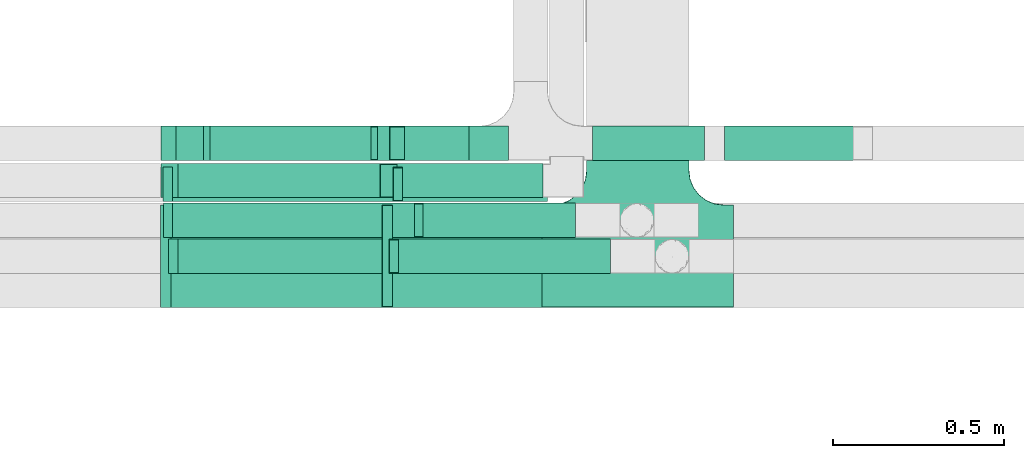
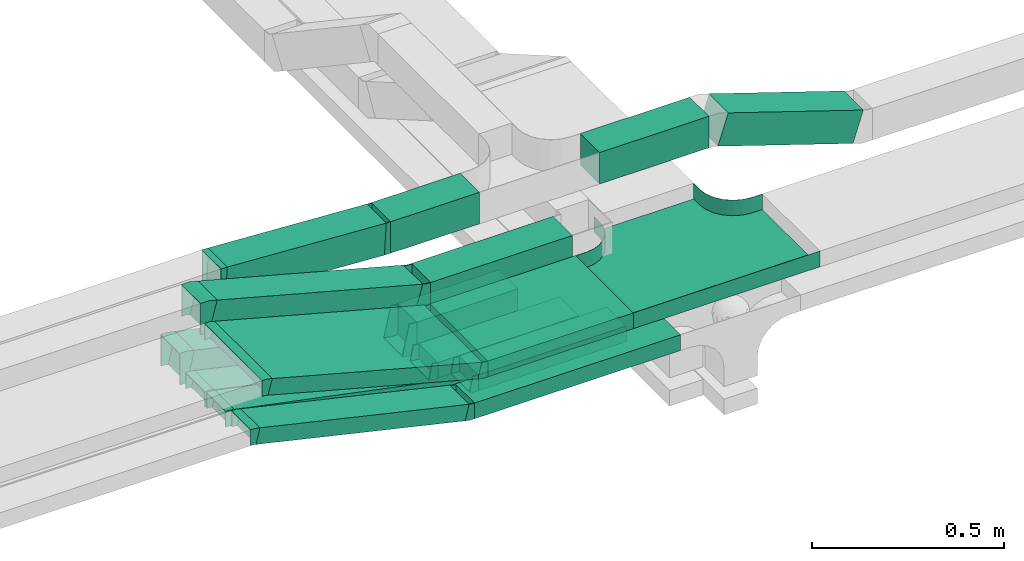
# One storey, part 10 of 14: 16 flow segments, 15 flow fittings.
"""IFC2X3 building model written with IfcOpenShell, lengths in millimetres."""

from ifc_helpers import new_model, entity, si_unit, converted_unit, derived_unit, direction, frame, frame_2d, origin, origin_2d_with_axis, place, context, subcontext, project, spatial, rectangle, extrude, faceted_brep, source, transform, mapped, material, type_object, type_shapes, element, save


model = new_model("IFC2X3")

# Units and contexts
model_context = context("Model", 3, precision=0.01, world=origin(), true_north=direction((6.12303176911189e-17, 1.0)))
body_context = subcontext(model_context, "Body", "Model", "MODEL_VIEW")
ifc_project = project(units=[si_unit("LENGTHUNIT", "METRE", prefix="MILLI"), si_unit("AREAUNIT", "SQUARE_METRE"), si_unit("VOLUMEUNIT", "CUBIC_METRE"), converted_unit("PLANEANGLEUNIT", "DEGREE", entity("IfcRatioMeasure", 0.0174532925199433), si_unit("PLANEANGLEUNIT", "RADIAN"), dimensions=[0, 0, 0, 0, 0, 0, 0]), si_unit("MASSUNIT", "GRAM", prefix="KILO"), derived_unit("MASSDENSITYUNIT", [(si_unit("MASSUNIT", "GRAM", prefix="KILO"), 1), (si_unit("LENGTHUNIT", "METRE"), -3)]), derived_unit("MOMENTOFINERTIAUNIT", [(si_unit("LENGTHUNIT", "METRE"), 4)]), si_unit("TIMEUNIT", "SECOND"), si_unit("FREQUENCYUNIT", "HERTZ"), si_unit("THERMODYNAMICTEMPERATUREUNIT", "DEGREE_CELSIUS"), derived_unit("THERMALTRANSMITTANCEUNIT", [(si_unit("MASSUNIT", "GRAM", prefix="KILO"), 1), (si_unit("THERMODYNAMICTEMPERATUREUNIT", "KELVIN"), -1), (si_unit("TIMEUNIT", "SECOND"), -3)]), derived_unit("VOLUMETRICFLOWRATEUNIT", [(si_unit("LENGTHUNIT", "METRE"), 3), (si_unit("TIMEUNIT", "SECOND"), -1)]), derived_unit("MASSFLOWRATEUNIT", [(si_unit("MASSUNIT", "GRAM", prefix="KILO"), 1), (si_unit("TIMEUNIT", "SECOND"), -1)]), derived_unit("ROTATIONALFREQUENCYUNIT", [(si_unit("TIMEUNIT", "SECOND"), -1)]), si_unit("ELECTRICCURRENTUNIT", "AMPERE"), si_unit("ELECTRICVOLTAGEUNIT", "VOLT"), si_unit("POWERUNIT", "WATT"), si_unit("FORCEUNIT", "NEWTON", prefix="KILO"), si_unit("ILLUMINANCEUNIT", "LUX"), si_unit("LUMINOUSFLUXUNIT", "LUMEN"), si_unit("LUMINOUSINTENSITYUNIT", "CANDELA"), derived_unit("USERDEFINED", [(si_unit("MASSUNIT", "GRAM", prefix="KILO"), -1), (si_unit("LENGTHUNIT", "METRE"), -2), (si_unit("TIMEUNIT", "SECOND"), 3), (si_unit("LUMINOUSFLUXUNIT", "LUMEN"), 1)]), derived_unit("LINEARVELOCITYUNIT", [(si_unit("LENGTHUNIT", "METRE"), 1), (si_unit("TIMEUNIT", "SECOND"), -1)]), si_unit("PRESSUREUNIT", "PASCAL"), derived_unit("USERDEFINED", [(si_unit("LENGTHUNIT", "METRE"), -2), (si_unit("MASSUNIT", "GRAM", prefix="KILO"), 1), (si_unit("TIMEUNIT", "SECOND"), -2)]), derived_unit("LINEARFORCEUNIT", [(si_unit("MASSUNIT", "GRAM", prefix="KILO"), 1), (si_unit("LENGTHUNIT", "METRE"), 1), (si_unit("TIMEUNIT", "SECOND"), -2), (si_unit("LENGTHUNIT", "METRE"), -1)]), derived_unit("PLANARFORCEUNIT", [(si_unit("MASSUNIT", "GRAM", prefix="KILO"), 1), (si_unit("LENGTHUNIT", "METRE"), 1), (si_unit("TIMEUNIT", "SECOND"), -2), (si_unit("LENGTHUNIT", "METRE"), -2)])], contexts=[model_context])

# Site, building, storey
site_placement = place(None, origin())
site = spatial("IfcSite", under=ifc_project, at=site_placement, CompositionType="ELEMENT")
building_placement = place(site_placement, origin())
building = spatial("IfcBuilding", under=site, at=building_placement, CompositionType="ELEMENT")
storey_placement = place(building_placement, frame((0.0, 0.0, 19800.0)))
storey = spatial("IfcBuildingStorey", under=building, at=storey_placement, Name="06", CompositionType="ELEMENT", Elevation=19800.0)

# Flow segments
cable_carrier_segment_type = type_object("IfcCableCarrierSegmentType", PredefinedType="CABLETRAYSEGMENT")
flow_segment_1_placement = place(storey_placement, frame((63840.22, 9836.0, 3000.0)))
element("IfcFlowSegment", 1, at=flow_segment_1_placement, inside=storey, type_object=cable_carrier_segment_type, context=body_context, shape_type="SweptSolid", body=[
    extrude(rectangle(XDim=425.328821775626, YDim=99.9999999999989, at=origin_2d_with_axis()), frame((212.66, 50.0, 0.0), z_axis=(0.0, 0.0, 1.0), x_axis=(-1.0, -2.08689464395144e-08, 0.0)), (0.0, 0.0, 1.0), 100.000000000008),
])
flow_segment_2_placement = place(storey_placement, frame((63916.07, 9720.0, 2800.0)))
element("IfcFlowSegment", 2, at=flow_segment_2_placement, inside=storey, type_object=cable_carrier_segment_type, context=body_context, shape_type="SweptSolid", body=[
    extrude(rectangle(XDim=444.461560115162, YDim=99.9999999999989, at=origin_2d_with_axis()), frame((222.23, 50.0, 0.0), z_axis=(0.0, 0.0, 1.0), x_axis=(-1.0, 0.0, 0.0)), (0.0, 0.0, 1.0), 49.9999999999973),
])
flow_segment_3_placement = place(storey_placement, frame((63861.59, 9945.0, 2800.0)))
element("IfcFlowSegment", 3, at=flow_segment_3_placement, inside=storey, type_object=cable_carrier_segment_type, context=body_context, shape_type="SweptSolid", body=[
    extrude(rectangle(XDim=303.534093712912, YDim=99.9999999999989, at=origin_2d_with_axis()), frame((151.77, 50.0, 0.0)), (0.0, 0.0, 1.0), 100.000000000003),
])
flow_segment_4_placement = place(storey_placement, frame((63844.36, 9615.0, 2800.0)))
element("IfcFlowSegment", 4, at=flow_segment_4_placement, inside=storey, type_object=cable_carrier_segment_type, context=body_context, shape_type="SweptSolid", body=[
    extrude(rectangle(XDim=618.676195552314, YDim=100.000000000001, at=origin_2d_with_axis()), frame((309.34, 50.0, 0.0), z_axis=(0.0, 0.0, 1.0), x_axis=(-1.0, 0.0, 0.0)), (0.0, 0.0, 1.0), 49.9999999999973),
])
flow_segment_5_placement = place(storey_placement, frame((64765.17, 9945.0, 3009.28)))
element("IfcFlowSegment", 5, at=flow_segment_5_placement, inside=storey, type_object=cable_carrier_segment_type, context=body_context, shape_type="SweptSolid", body=[
    extrude(rectangle(XDim=99.9999999999972, YDim=99.9999999999989, at=origin_2d_with_axis()), frame((15.59, 50.0, 180.61), z_axis=(0.950175096611784, 0.0, -0.311716675490399), x_axis=(0.311716675490399, 0.0, 0.950175096611784)), (0.0, 0.0, 1.0), 426.997112921798),
])
flow_segment_6_placement = place(storey_placement, frame((64410.06, 9945.0, 3146.68)))
element("IfcFlowSegment", 6, at=flow_segment_6_placement, inside=storey, type_object=cable_carrier_segment_type, context=body_context, shape_type="SweptSolid", body=[
    extrude(rectangle(XDim=328.216762954596, YDim=99.9999999999989, at=origin_2d_with_axis()), frame((164.11, 50.0, 0.0)), (0.0, 0.0, 1.0), 100.000000000003),
])
flow_segment_7_placement = place(storey_placement, frame((63826.54, 9515.0, 3000.0)))
element("IfcFlowSegment", 7, at=flow_segment_7_placement, inside=storey, type_object=cable_carrier_segment_type, context=body_context, shape_type="SweptSolid", body=[
    extrude(rectangle(XDim=436.498088942979, YDim=300.000000000001, at=origin_2d_with_axis()), frame((218.25, 150.0, 0.0), z_axis=(0.0, 0.0, 1.0), x_axis=(-1.0, 0.0, 0.0)), (0.0, 0.0, 1.0), 49.9999999999973),
])
flow_segment_8_placement = place(storey_placement, frame((63173.53, 9836.0, 3006.58)))
element("IfcFlowSegment", 8, at=flow_segment_8_placement, inside=storey, type_object=cable_carrier_segment_type, context=body_context, shape_type="SweptSolid", body=[
    extrude(rectangle(XDim=99.999999999999, YDim=99.9999999999989, at=frame_2d((0.0, 0.0), x_axis=(0.0, 1.0))), frame((12.94, 50.0, 213.55), z_axis=(0.965925826289069, 0.0, -0.258819045102519), x_axis=(0.0, 1.0, 0.0)), (0.0, 0.0, 1.0), 638.501182800934),
])
flow_segment_9_placement = place(storey_placement, frame((63166.54, 9515.0, 3004.02)))
element("IfcFlowSegment", 9, at=flow_segment_9_placement, inside=storey, type_object=cable_carrier_segment_type, context=body_context, shape_type="SweptSolid", body=[
    extrude(rectangle(XDim=49.9999999999985, YDim=299.999999999999, at=origin_2d_with_axis()), frame((6.47, 150.0, 192.81), z_axis=(0.96592582628904, 4.1991581397727e-08, -0.258819045102621), x_axis=(0.258819045102621, 1.19570188417132e-08, 0.965925826289041)), (0.0, 0.0, 1.0), 651.666301653679),
])
flow_segment_10_placement = place(storey_placement, frame((63855.59, 9825.0, 2797.27)))
element("IfcFlowSegment", 10, at=flow_segment_10_placement, inside=storey, type_object=cable_carrier_segment_type, context=body_context, shape_type="SweptSolid", body=[
    extrude(rectangle(XDim=423.413526170801, YDim=99.9999999999989, at=origin_2d_with_axis()), frame((211.71, 50.0, 0.0)), (0.0, 0.0, 1.0), 49.9999999999973),
])
flow_segment_11_placement = place(storey_placement, frame((63171.78, 9945.0, 2804.73)))
element("IfcFlowSegment", 11, at=flow_segment_11_placement, inside=storey, type_object=cable_carrier_segment_type, context=body_context, shape_type="SweptSolid", body=[
    extrude(rectangle(XDim=100.000000000001, YDim=99.9999999999989, at=origin_2d_with_axis()), frame((10.79, 50.0, 191.71), z_axis=(0.976432143455112, 0.0, -0.215824626091779), x_axis=(0.215824626091779, 0.0, 0.976432143455112)), (0.0, 0.0, 1.0), 662.076920748981),
])
flow_segment_12_placement = place(storey_placement, frame((63172.09, 9825.0, 2800.33)))
element("IfcFlowSegment", 12, at=flow_segment_12_placement, inside=storey, type_object=cable_carrier_segment_type, context=body_context, shape_type="SweptSolid", body=[
    extrude(rectangle(XDim=49.9999999999987, YDim=99.9999999999989, at=origin_2d_with_axis()), frame((5.5, 50.0, 172.23), z_axis=(0.975535107739087, 0.0, -0.219843702590016), x_axis=(0.219843702590016, 0.0, 0.975535107739087)), (0.0, 0.0, 1.0), 672.484845813167),
])
flow_segment_13_placement = place(storey_placement, frame((63173.63, 9720.0, 2802.6)))
element("IfcFlowSegment", 13, at=flow_segment_13_placement, inside=storey, type_object=cable_carrier_segment_type, context=body_context, shape_type="SweptSolid", body=[
    extrude(rectangle(XDim=50.0000000000011, YDim=100.0, at=origin_2d_with_axis()), frame((4.98, 50.0, 170.3), z_axis=(0.979923045991076, 0.0, -0.199376086669318), x_axis=(0.199376086669318, 0.0, 0.979923045991076)), (0.0, 0.0, 1.0), 731.270116832418),
])
flow_segment_14_placement = place(storey_placement, frame((63188.73, 9615.0, 2803.18)))
element("IfcFlowSegment", 14, at=flow_segment_14_placement, inside=storey, type_object=cable_carrier_segment_type, context=body_context, shape_type="SweptSolid", body=[
    extrude(rectangle(XDim=49.9999999999962, YDim=99.9999999999989, at=origin_2d_with_axis()), frame((5.62, 50.0, 169.29), z_axis=(0.974370064785255, 0.0, -0.224951054343782), x_axis=(0.224951054343782, 0.0, 0.974370064785255)), (0.0, 0.0, 1.0), 644.278805474705),
])
flow_segment_15_placement = place(storey_placement, frame((63783.07, 9945.0, 3146.68)))
element("IfcFlowSegment", 15, at=flow_segment_15_placement, inside=storey, type_object=cable_carrier_segment_type, context=body_context, shape_type="SweptSolid", body=[
    extrude(rectangle(XDim=266.988683525038, YDim=99.9999999999989, at=origin_2d_with_axis()), frame((133.49, 50.0, 0.0), z_axis=(0.0, 0.0, 1.0), x_axis=(-1.0, 0.0, 0.0)), (0.0, 0.0, 1.0), 100.000000000003),
])
flow_segment_16_placement = place(storey_placement, frame((63286.9, 9945.0, 3147.22)))
element("IfcFlowSegment", 16, at=flow_segment_16_placement, inside=storey, type_object=cable_carrier_segment_type, context=body_context, shape_type="SweptSolid", body=[
    extrude(rectangle(XDim=100.000000000003, YDim=99.9999999999989, at=frame_2d((0.0, 0.0), x_axis=(0.0, 1.0))), frame((2.87, 50.0, 77.32), z_axis=(0.998356358345245, 0.0, -0.0573112707206922), x_axis=(0.0, 1.0, 0.0)), (0.0, 0.0, 1.0), 478.077091125566),
])

# Flow fittings
ifc_material = material()
cable_carrier_fitting_type_1 = type_object("IfcCableCarrierFittingType", PredefinedType="NOTDEFINED", material=ifc_material)
shared_shape_1 = source(origin(), body_context, "Body", "Brep", [
    faceted_brep([(-153.41, -224.12, 25.0), (-150.0, -250.0, 25.0), (-150.0, -280.0, 25.0), (-149.2, -280.0, 25.0), (-149.2, -250.0, 25.0), (-152.63, -223.91, 25.0), (-162.7, -199.6, 25.0), (-178.72, -178.72, 25.0), (-199.6, -162.7, 25.0), (-223.91, -152.63, 25.0), (-250.0, -149.2, 25.0), (-280.0, -149.2, 25.0), (-280.0, -150.0, 25.0), (-250.0, -150.0, 25.0), (-224.12, -153.41, 25.0), (-200.0, -163.4, 25.0), (-179.29, -179.29, 25.0), (-163.4, -200.0, 25.0), (280.0, -150.0, 25.0), (280.0, -149.2, 25.0), (250.0, -149.2, 25.0), (223.91, -152.63, 25.0), (199.6, -162.7, 25.0), (178.72, -178.72, 25.0), (162.7, -199.6, 25.0), (152.63, -223.91, 25.0), (149.2, -250.0, 25.0), (149.2, -280.0, 25.0), (150.0, -280.0, 25.0), (150.0, -250.0, 25.0), (153.41, -224.12, 25.0), (163.4, -200.0, 25.0), (179.29, -179.29, 25.0), (200.0, -163.4, 25.0), (224.12, -153.41, 25.0), (250.0, -150.0, 25.0), (280.0, 149.2, 25.0), (280.0, 150.0, 25.0), (-280.0, 150.0, 25.0), (-280.0, 149.2, 25.0), (-280.0, -150.0, -25.0), (-280.0, 150.0, -25.0), (280.0, 150.0, -25.0), (280.0, -150.0, -25.0), (250.0, -150.0, -25.0), (224.12, -153.41, -25.0), (200.0, -163.4, -25.0), (179.29, -179.29, -25.0), (163.4, -200.0, -25.0), (153.41, -224.12, -25.0), (150.0, -250.0, -25.0), (150.0, -280.0, -25.0), (-150.0, -280.0, -25.0), (-150.0, -250.0, -25.0), (-153.41, -224.12, -25.0), (-163.4, -200.0, -25.0), (-179.29, -179.29, -25.0), (-200.0, -163.4, -25.0), (-224.12, -153.41, -25.0), (-250.0, -150.0, -25.0), (-150.0, -250.0, -24.2), (149.2, -280.0, -24.2), (-149.2, -280.0, -24.2), (-149.2, -250.0, -24.2), (-250.0, -149.2, -24.2), (-280.0, -149.2, -24.2), (280.0, -149.2, -24.2), (250.0, -149.2, -24.2), (-280.0, 149.2, -24.2), (-250.0, -150.0, -24.2), (250.0, -150.0, -24.2), (280.0, 149.2, -24.2), (149.2, -250.0, -24.2), (150.0, -250.0, -24.2), (-223.91, -152.63, -24.2), (-199.6, -162.7, -24.2), (-178.72, -178.72, -24.2), (-162.7, -199.6, -24.2), (-152.63, -223.91, -24.2), (152.63, -223.91, -24.2), (162.7, -199.6, -24.2), (178.72, -178.72, -24.2), (199.6, -162.7, -24.2), (223.91, -152.63, -24.2)], [[[0, 1, 2, 3, 4, 5, 6, 7, 8, 9, 10, 11, 12, 13, 14, 15, 16, 17]], [[18, 19, 20, 21, 22, 23, 24, 25, 26, 27, 28, 29, 30, 31, 32, 33, 34, 35]], [[36, 37, 38, 39]], [[40, 41, 42, 43, 44, 45, 46, 47, 48, 49, 50, 51, 52, 53, 54, 55, 56, 57, 58, 59]], [[2, 1, 60, 53, 52]], [[3, 2, 52, 51, 28, 27, 61, 62]], [[4, 3, 62, 63]], [[11, 10, 64, 65]], [[20, 19, 66, 67]], [[39, 38, 41, 40, 12, 11, 65, 68]], [[13, 12, 40, 59, 69]], [[18, 35, 70, 44, 43]], [[19, 18, 43, 42, 37, 36, 71, 66]], [[27, 26, 72, 61]], [[29, 28, 51, 50, 73]], [[38, 37, 42, 41]], [[36, 39, 68, 71]], [[68, 65, 64, 74, 75, 76, 77, 78, 63, 62, 61, 72, 79, 80, 81, 82, 83, 67, 66, 71]], [[14, 13, 69, 59, 58]], [[58, 57, 15, 14]], [[15, 57, 56, 16]], [[0, 17, 55, 54]], [[0, 54, 53, 60, 1]], [[55, 17, 16, 56]], [[5, 4, 63, 78]], [[6, 5, 78, 77]], [[7, 6, 77, 76]], [[8, 7, 76, 75]], [[9, 8, 75, 74]], [[10, 9, 74, 64]], [[21, 20, 67, 83]], [[22, 21, 83, 82]], [[23, 22, 82, 81]], [[81, 80, 24, 23]], [[24, 80, 79, 25]], [[79, 72, 26, 25]], [[30, 29, 73, 50, 49]], [[31, 30, 49, 48]], [[31, 48, 47, 32]], [[33, 32, 47, 46]], [[45, 34, 33, 46]], [[34, 45, 44, 70, 35]]]),
])
type_shapes(cable_carrier_fitting_type_1, [shared_shape_1])
flow_fitting_placement = place(storey_placement, frame((64543.04, 9665.0, 3025.0), z_axis=(0.0, 0.0, 1.0), x_axis=(-1.0, 0.0, 0.0)))
element("IfcFlowFitting", 17, at=flow_fitting_placement, inside=storey, type_object=cable_carrier_fitting_type_1, material=ifc_material, Name="470_DKC_S5_T", context=body_context, shape_type="MappedRepresentation", body=[
    mapped(shared_shape_1, transform((0.0, 0.0, 0.0), scale=1.0)),
])
cable_carrier_fitting_type_2 = type_object("IfcCableCarrierFittingType", PredefinedType="NOTDEFINED", material=ifc_material)
shared_shape_2 = source(origin(), body_context, "Body", "Brep", [
    faceted_brep([(-12.24, -25.0, 150.0), (-12.24, 25.0, 150.0), (-12.24, 25.0, 147.46), (-12.24, -22.46, 147.46), (-12.24, -22.46, -147.46), (-12.24, 25.0, -147.46), (-12.24, 25.0, -150.0), (-12.24, -25.0, -150.0), (18.29, -20.98, 150.0), (18.29, -20.98, -150.0), (5.35, 27.32, -150.0), (5.35, 27.32, -147.46), (17.64, -18.53, -147.46), (17.64, -18.53, 147.46), (5.35, 27.32, 147.46), (5.35, 27.32, 150.0), (3.29, -25.0, 150.0), (-3.29, 25.0, 150.0), (-3.29, 25.0, 147.46), (2.96, -22.46, 147.46), (2.96, -22.46, -147.46), (-3.29, 25.0, -147.46), (-3.29, 25.0, -150.0), (3.29, -25.0, -150.0)], [[[0, 1, 2, 3, 4, 5, 6, 7]], [[8, 9, 10, 11, 12, 13, 14, 15]], [[1, 0, 16, 8, 15, 17]], [[2, 1, 17, 18]], [[3, 2, 18, 14, 13, 19]], [[4, 3, 19, 20]], [[5, 4, 20, 12, 11, 21]], [[6, 5, 21, 22]], [[7, 6, 22, 10, 9, 23]], [[0, 7, 23, 16]], [[18, 17, 15, 14]], [[20, 19, 13, 12]], [[22, 21, 11, 10]], [[16, 23, 9, 8]]]),
])
type_shapes(cable_carrier_fitting_type_2, [shared_shape_2])
for number, where, z_axis, x_axis in (
    (18, (63814.3, 9665.0, 3025.0), (0.0, 1.0, 1.62242993821036e-07), (-1.0, 0.0, 0.0)),
    (19, (63161.19, 9665.0, 3200.0), (0.0, -1.0, -1.62242998689715e-07), (-0.965925826289063, -4.19915779954446e-08, 0.258819045102537)),
):
    element("IfcFlowFitting", number, at=place(storey_placement, frame(where, z_axis=z_axis, x_axis=x_axis)), inside=storey, type_object=cable_carrier_fitting_type_2, material=ifc_material, context=body_context, shape_type="MappedRepresentation", body=[
        mapped(shared_shape_2, transform((0.0, 0.0, 0.0), scale=1.0)),
    ])
cable_carrier_fitting_type_3 = type_object("IfcCableCarrierFittingType", PredefinedType="NOTDEFINED", material=ifc_material)
shared_shape_3 = source(origin(), body_context, "Body", "Brep", [
    faceted_brep([(-8.01, -50.0, 50.0), (-8.01, 50.0, 50.0), (-8.01, 50.0, 47.46), (-8.01, -47.46, 47.46), (-8.01, -47.46, -47.46), (-8.01, 50.0, -47.46), (-8.01, 50.0, -50.0), (-8.01, -50.0, -50.0), (10.86, -49.46, 50.0), (10.86, -49.46, -50.0), (5.13, 50.38, -50.0), (5.13, 50.38, -47.46), (10.72, -46.92, -47.46), (10.72, -46.92, 47.46), (5.13, 50.38, 47.46), (5.13, 50.38, 50.0), (1.43, -50.0, 50.0), (-1.43, 50.0, 50.0), (-1.43, 50.0, 47.46), (1.36, -47.46, 47.46), (1.36, -47.46, -47.46), (-1.43, 50.0, -47.46), (-1.43, 50.0, -50.0), (1.43, -50.0, -50.0)], [[[0, 1, 2, 3, 4, 5, 6, 7]], [[8, 9, 10, 11, 12, 13, 14, 15]], [[1, 0, 16, 8, 15, 17]], [[2, 1, 17, 18]], [[3, 2, 18, 14, 13, 19]], [[4, 3, 19, 20]], [[5, 4, 20, 12, 11, 21]], [[6, 5, 21, 22]], [[7, 6, 22, 10, 9, 23]], [[0, 7, 23, 16]], [[18, 17, 15, 14]], [[20, 19, 13, 12]], [[22, 21, 11, 10]], [[16, 23, 9, 8]]]),
])
type_shapes(cable_carrier_fitting_type_3, [shared_shape_3])
for number, where, z_axis, x_axis in (
    (20, (63281.77, 9995.0, 3225.0), (0.0, 1.0, 0.0), (1.0, 0.0, 0.0)),
    (21, (63775.06, 9995.0, 3196.68), (0.0, 1.0, 0.0), (-1.0, 0.0, 0.0)),
):
    element("IfcFlowFitting", number, at=place(storey_placement, frame(where, z_axis=z_axis, x_axis=x_axis)), inside=storey, type_object=cable_carrier_fitting_type_3, material=ifc_material, context=body_context, shape_type="MappedRepresentation", body=[
        mapped(shared_shape_3, transform((0.0, 0.0, 0.0), scale=1.0)),
    ])
cable_carrier_fitting_type_4 = type_object("IfcCableCarrierFittingType", PredefinedType="NOTDEFINED", material=ifc_material)
shared_shape_4 = source(origin(), body_context, "Body", "Brep", [
    faceted_brep([(-18.82, -50.0, 50.0), (-18.82, 50.0, 50.0), (-18.82, 50.0, 47.46), (-18.82, -47.46, 47.46), (-18.82, -47.46, -47.46), (-18.82, 50.0, -47.46), (-18.82, 50.0, -50.0), (-18.82, -50.0, -50.0), (31.12, -43.42, 50.0), (31.12, -43.42, -50.0), (5.24, 53.17, -50.0), (5.24, 53.17, -47.46), (30.47, -40.97, -47.46), (30.47, -40.97, 47.46), (5.24, 53.17, 47.46), (5.24, 53.17, 50.0), (6.58, -50.0, 50.0), (-6.58, 50.0, 50.0), (-6.58, 50.0, 47.46), (6.25, -47.46, 47.46), (6.25, -47.46, -47.46), (-6.58, 50.0, -47.46), (-6.58, 50.0, -50.0), (6.58, -50.0, -50.0)], [[[0, 1, 2, 3, 4, 5, 6, 7]], [[8, 9, 10, 11, 12, 13, 14, 15]], [[1, 0, 16, 8, 15, 17]], [[2, 1, 17, 18]], [[3, 2, 18, 14, 13, 19]], [[4, 3, 19, 20]], [[5, 4, 20, 12, 11, 21]], [[6, 5, 21, 22]], [[7, 6, 22, 10, 9, 23]], [[0, 7, 23, 16]], [[18, 17, 15, 14]], [[20, 19, 13, 12]], [[22, 21, 11, 10]], [[16, 23, 9, 8]]]),
])
type_shapes(cable_carrier_fitting_type_4, [shared_shape_4])
for number, where, z_axis, x_axis in (
    (22, (63168.29, 9886.0, 3225.0), (0.0, 1.0, 0.0), (1.0, 0.0, 0.0)),
    (23, (63821.39, 9886.0, 3050.0), (2.08688699966324e-08, -1.0, 7.78836831239711e-08), (0.965925826289059, 0.0, -0.258819045102554)),
):
    element("IfcFlowFitting", number, at=place(storey_placement, frame(where, z_axis=z_axis, x_axis=x_axis)), inside=storey, type_object=cable_carrier_fitting_type_4, material=ifc_material, context=body_context, shape_type="MappedRepresentation", body=[
        mapped(shared_shape_4, transform((0.0, 0.0, 0.0), scale=1.0)),
    ])
cable_carrier_fitting_type_5 = type_object("IfcCableCarrierFittingType", PredefinedType="NOTDEFINED", material=ifc_material)
shared_shape_5 = source(origin(), body_context, "Body", "Brep", [
    faceted_brep([(-11.27, -25.0, 50.0), (-11.27, 25.0, 50.0), (-11.27, 25.0, 47.46), (-11.27, -22.46, 47.46), (-11.27, -22.46, -47.46), (-11.27, 25.0, -47.46), (-11.27, 25.0, -50.0), (-11.27, -25.0, -50.0), (16.6, -21.82, 50.0), (16.6, -21.82, -50.0), (5.35, 26.89, -50.0), (5.35, 26.89, -47.46), (16.03, -19.35, -47.46), (16.03, -19.35, 47.46), (5.35, 26.89, 47.46), (5.35, 26.89, 50.0), (2.85, -25.0, 50.0), (-2.85, 25.0, 50.0), (-2.85, 25.0, 47.46), (2.56, -22.46, 47.46), (2.56, -22.46, -47.46), (-2.85, 25.0, -47.46), (-2.85, 25.0, -50.0), (2.85, -25.0, -50.0)], [[[0, 1, 2, 3, 4, 5, 6, 7]], [[8, 9, 10, 11, 12, 13, 14, 15]], [[1, 0, 16, 8, 15, 17]], [[2, 1, 17, 18]], [[3, 2, 18, 14, 13, 19]], [[4, 3, 19, 20]], [[5, 4, 20, 12, 11, 21]], [[6, 5, 21, 22]], [[7, 6, 22, 10, 9, 23]], [[0, 7, 23, 16]], [[18, 17, 15, 14]], [[20, 19, 13, 12]], [[22, 21, 11, 10]], [[16, 23, 9, 8]]]),
])
type_shapes(cable_carrier_fitting_type_5, [shared_shape_5])
for number, where, z_axis, x_axis in (
    (24, (63833.1, 9665.0, 2825.0), (0.0, 1.0, 0.0), (-1.0, 0.0, 0.0)),
    (25, (63183.37, 9665.0, 2975.0), (0.0, -1.0, 0.0), (-0.974370064785237, 0.0, 0.22495105434386)),
):
    element("IfcFlowFitting", number, at=place(storey_placement, frame(where, z_axis=z_axis, x_axis=x_axis)), inside=storey, type_object=cable_carrier_fitting_type_5, material=ifc_material, context=body_context, shape_type="MappedRepresentation", body=[
        mapped(shared_shape_5, transform((0.0, 0.0, 0.0), scale=1.0)),
    ])
cable_carrier_fitting_type_6 = type_object("IfcCableCarrierFittingType", PredefinedType="NOTDEFINED", material=ifc_material)
shared_shape_6 = source(origin(), body_context, "Body", "Brep", [
    faceted_brep([(-10.54, -25.0, 50.0), (-10.54, 25.0, 50.0), (-10.54, 25.0, 47.46), (-10.54, -22.46, 47.46), (-10.54, -22.46, -47.46), (-10.54, 25.0, -47.46), (-10.54, 25.0, -50.0), (-10.54, -25.0, -50.0), (15.31, -22.4, 50.0), (15.31, -22.4, -50.0), (5.34, 26.6, -50.0), (5.34, 26.6, -47.46), (14.8, -19.91, -47.46), (14.8, -19.91, 47.46), (5.34, 26.6, 47.46), (5.34, 26.6, 50.0), (2.52, -25.0, 50.0), (-2.52, 25.0, 50.0), (-2.52, 25.0, 47.46), (2.26, -22.46, 47.46), (2.26, -22.46, -47.46), (-2.52, 25.0, -47.46), (-2.52, 25.0, -50.0), (2.52, -25.0, -50.0)], [[[0, 1, 2, 3, 4, 5, 6, 7]], [[8, 9, 10, 11, 12, 13, 14, 15]], [[1, 0, 16, 8, 15, 17]], [[2, 1, 17, 18]], [[3, 2, 18, 14, 13, 19]], [[4, 3, 19, 20]], [[5, 4, 20, 12, 11, 21]], [[6, 5, 21, 22]], [[7, 6, 22, 10, 9, 23]], [[0, 7, 23, 16]], [[18, 17, 15, 14]], [[20, 19, 13, 12]], [[22, 21, 11, 10]], [[16, 23, 9, 8]]]),
])
type_shapes(cable_carrier_fitting_type_6, [shared_shape_6])
for number, where, z_axis, x_axis in (
    (26, (63905.53, 9770.0, 2825.0), (0.0, 1.0, 0.0), (-1.0, 0.0, 0.0)),
    (27, (63168.29, 9770.0, 2975.0), (0.0, -1.0, 0.0), (-0.979923045991058, 0.0, 0.199376086669409)),
):
    element("IfcFlowFitting", number, at=place(storey_placement, frame(where, z_axis=z_axis, x_axis=x_axis)), inside=storey, type_object=cable_carrier_fitting_type_6, material=ifc_material, context=body_context, shape_type="MappedRepresentation", body=[
        mapped(shared_shape_6, transform((0.0, 0.0, 0.0), scale=1.0)),
    ])
cable_carrier_fitting_type_7 = type_object("IfcCableCarrierFittingType", PredefinedType="NOTDEFINED", material=ifc_material)
shared_shape_7 = source(origin(), body_context, "Body", "Brep", [
    faceted_brep([(-11.12, -25.0, 50.0), (-11.12, 25.0, 50.0), (-11.12, 25.0, 47.46), (-11.12, -22.46, 47.46), (-11.12, -22.46, -47.46), (-11.12, 25.0, -47.46), (-11.12, 25.0, -50.0), (-11.12, -25.0, -50.0), (16.34, -21.94, 50.0), (16.34, -21.94, -50.0), (5.35, 26.83, -50.0), (5.35, 26.83, -47.46), (15.79, -19.47, -47.46), (15.79, -19.47, 47.46), (5.35, 26.83, 47.46), (5.35, 26.83, 50.0), (2.78, -25.0, 50.0), (-2.78, 25.0, 50.0), (-2.78, 25.0, 47.46), (2.5, -22.46, 47.46), (2.5, -22.46, -47.46), (-2.78, 25.0, -47.46), (-2.78, 25.0, -50.0), (2.78, -25.0, -50.0)], [[[0, 1, 2, 3, 4, 5, 6, 7]], [[8, 9, 10, 11, 12, 13, 14, 15]], [[1, 0, 16, 8, 15, 17]], [[2, 1, 17, 18]], [[3, 2, 18, 14, 13, 19]], [[4, 3, 19, 20]], [[5, 4, 20, 12, 11, 21]], [[6, 5, 21, 22]], [[7, 6, 22, 10, 9, 23]], [[0, 7, 23, 16]], [[18, 17, 15, 14]], [[20, 19, 13, 12]], [[22, 21, 11, 10]], [[16, 23, 9, 8]]]),
])
type_shapes(cable_carrier_fitting_type_7, [shared_shape_7])
for number, where, z_axis, x_axis in (
    (28, (63844.47, 9875.0, 2822.27), (0.0, 1.0, 0.0), (-1.0, 0.0, 0.0)),
    (29, (63166.74, 9875.0, 2975.0), (0.0, -1.0, 0.0), (-0.975535107739096, 0.0, 0.219843702589976)),
):
    element("IfcFlowFitting", number, at=place(storey_placement, frame(where, z_axis=z_axis, x_axis=x_axis)), inside=storey, type_object=cable_carrier_fitting_type_7, material=ifc_material, context=body_context, shape_type="MappedRepresentation", body=[
        mapped(shared_shape_7, transform((0.0, 0.0, 0.0), scale=1.0)),
    ])
cable_carrier_fitting_type_8 = type_object("IfcCableCarrierFittingType", PredefinedType="NOTDEFINED", material=ifc_material)
shared_shape_8 = source(origin(), body_context, "Body", "Brep", [
    faceted_brep([(-16.47, -50.0, 50.0), (-16.47, 50.0, 50.0), (-16.47, 50.0, 47.46), (-16.47, -47.46, 47.46), (-16.47, -47.46, -47.46), (-16.47, 50.0, -47.46), (-16.47, 50.0, -50.0), (-16.47, -50.0, -50.0), (26.87, -45.27, 50.0), (26.87, -45.27, -50.0), (5.29, 52.38, -50.0), (5.29, 52.38, -47.46), (26.32, -42.79, -47.46), (26.32, -42.79, 47.46), (5.29, 52.38, 47.46), (5.29, 52.38, 50.0), (5.46, -50.0, 50.0), (-5.46, 50.0, 50.0), (-5.46, 50.0, 47.46), (5.18, -47.46, 47.46), (5.18, -47.46, -47.46), (-5.46, 50.0, -47.46), (-5.46, 50.0, -50.0), (5.46, -50.0, -50.0)], [[[0, 1, 2, 3, 4, 5, 6, 7]], [[8, 9, 10, 11, 12, 13, 14, 15]], [[1, 0, 16, 8, 15, 17]], [[2, 1, 17, 18]], [[3, 2, 18, 14, 13, 19]], [[4, 3, 19, 20]], [[5, 4, 20, 12, 11, 21]], [[6, 5, 21, 22]], [[7, 6, 22, 10, 9, 23]], [[0, 7, 23, 16]], [[18, 17, 15, 14]], [[20, 19, 13, 12]], [[22, 21, 11, 10]], [[16, 23, 9, 8]]]),
])
type_shapes(cable_carrier_fitting_type_8, [shared_shape_8])
for number, where, z_axis, x_axis in (
    (30, (63845.12, 9995.0, 2850.0), (0.0, 1.0, 0.0), (-1.0, 0.0, 0.0)),
    (31, (63166.49, 9995.0, 3000.0), (0.0, 1.0, 0.0), (1.0, 0.0, 0.0)),
):
    element("IfcFlowFitting", number, at=place(storey_placement, frame(where, z_axis=z_axis, x_axis=x_axis)), inside=storey, type_object=cable_carrier_fitting_type_8, material=ifc_material, context=body_context, shape_type="MappedRepresentation", body=[
        mapped(shared_shape_8, transform((0.0, 0.0, 0.0), scale=1.0)),
    ])

save(model, "model.ifc")
